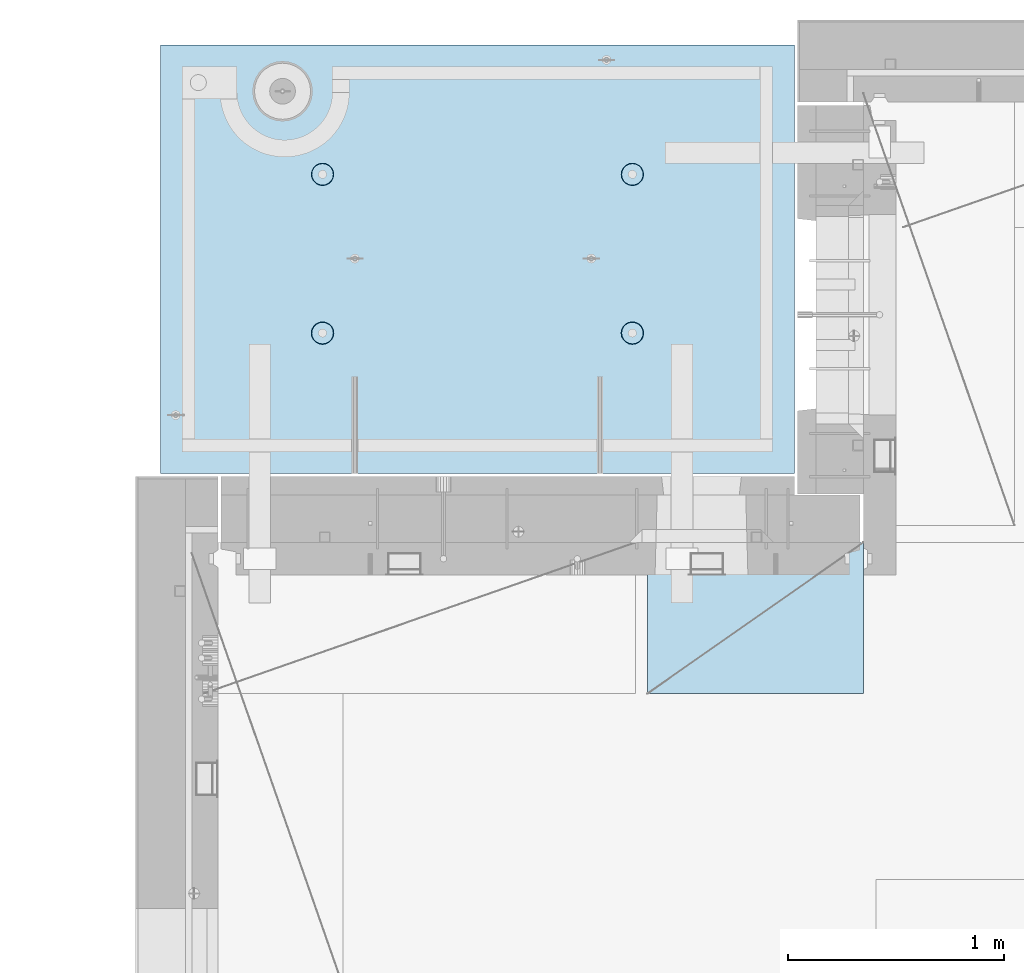
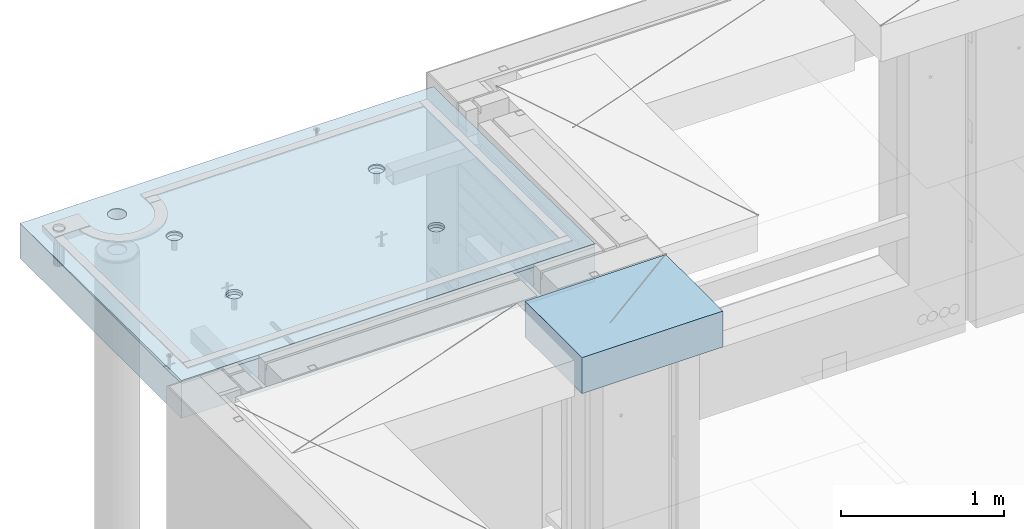
# One storey, part 205 of 349: 2 slabs, 1 plate, 2 elements without a shape of their own.
"""IFC2X3 building model written with IfcOpenShell, lengths in millimetres."""

import ifcopenshell
import ifcopenshell.guid

model = None  # the IFC model being written
_history = None  # IfcOwnerHistory: only IFC2X3 demands one
_inside = {}  # id of a spatial element -> (the spatial element, [elements in it])
_under = {}  # id of a project, library or spatial element -> (it, [spatial elements below it])
_declared = {}  # id of a project -> (the project, [libraries it declares])
_typed = {}  # id of a type object -> (the type object, [elements of that type])
_made_of = {}  # id of a material, layer set ... -> (it, [elements and type objects made of it])


def new_model(schema):
    """Start an empty IFC model of exactly this schema.

    Asked for "IFC4X3", IfcOpenShell would pick the latest addendum, in which some entities
    have other attributes; the version numbers below select the first issue.
    IFC2X3 requires an IfcOwnerHistory on every rooted entity: one is made here for all.
    """
    global model, _history
    if schema == "IFC4X3":
        model = ifcopenshell.file(schema_version=(4, 3, 0, 0))
    else:
        model = ifcopenshell.file(schema=schema)
    _inside.clear()
    _under.clear()
    _declared.clear()
    _typed.clear()
    _made_of.clear()
    _history = None
    if model.schema == "IFC2X3":
        org = make("IfcOrganization", Name="unknown")
        user = make(
            "IfcPersonAndOrganization",
            ThePerson=make("IfcPerson", FamilyName="unknown"),
            TheOrganization=org,
        )
        app = make(
            "IfcApplication",
            ApplicationDeveloper=org,
            Version="unknown",
            ApplicationFullName="unknown",
            ApplicationIdentifier="unknown",
        )
        _history = make(
            "IfcOwnerHistory",
            OwningUser=user,
            OwningApplication=app,
            ChangeAction="ADDED",
            CreationDate=0,
        )
    return model


def make(cls, **values):
    """One entity of the class cls with the attributes given. An attribute that is None is left unset."""
    return model.create_entity(
        cls, **{name: value for name, value in values.items() if value is not None}
    )


def rooted(cls, **values):
    """An entity with a GlobalId (a new one), such as an element, a storey or a relation."""
    return make(cls, GlobalId=ifcopenshell.guid.new(), OwnerHistory=_history, **values)


def si_unit(unit_type, name, prefix=None):
    """IfcSIUnit, for example si_unit("LENGTHUNIT", "METRE", prefix="MILLI")."""
    return make("IfcSIUnit", UnitType=unit_type, Prefix=prefix, Name=name)


def assignment(units):
    """IfcUnitAssignment: the units of a project."""
    return None if units is None else make("IfcUnitAssignment", Units=units)


def point(xyz):
    """IfcCartesianPoint."""
    return None if xyz is None else make("IfcCartesianPoint", Coordinates=xyz)


def direction(xyz):
    """IfcDirection."""
    return None if xyz is None else make("IfcDirection", DirectionRatios=xyz)


def frame(location, z_axis=None, x_axis=None):
    """IfcAxis2Placement3D, a coordinate frame: its origin and axes. An axis left out is left unset."""
    return make(
        "IfcAxis2Placement3D",
        Location=point(location),
        Axis=direction(z_axis),
        RefDirection=direction(x_axis),
    )


def origin_with_axes():
    """The frame at (0, 0, 0) with the z axis (0, 0, 1) and the x axis (1, 0, 0) written out."""
    return frame((0.0, 0.0, 0.0), z_axis=(0.0, 0.0, 1.0), x_axis=(1.0, 0.0, 0.0))


def place(relative_to, where):
    """IfcLocalPlacement: puts the frame where relative to a parent placement (None: the world)."""
    return make(
        "IfcLocalPlacement", PlacementRelTo=relative_to, RelativePlacement=where
    )


def context(
    kind, dimensions, precision=None, world=None, true_north=None, identifier=None
):
    """IfcGeometricRepresentationContext, for example the 3D "Model" context."""
    return make(
        "IfcGeometricRepresentationContext",
        ContextIdentifier=identifier,
        ContextType=kind,
        CoordinateSpaceDimension=dimensions,
        Precision=precision,
        WorldCoordinateSystem=world,
        TrueNorth=true_north,
    )


def subcontext(parent, identifier, kind, view, scale=None):
    """IfcGeometricRepresentationSubContext, for example "Body" below "Model"."""
    return make(
        "IfcGeometricRepresentationSubContext",
        ContextIdentifier=identifier,
        ContextType=kind,
        ParentContext=parent,
        TargetScale=scale,
        TargetView=view,
    )


def project(units=None, contexts=None):
    """IfcProject with its units and contexts."""
    return rooted(
        "IfcProject",
        Name="project",
        RepresentationContexts=contexts,
        UnitsInContext=assignment(units),
    )


def spatial(cls, under=None, at=None, **own):
    """A site, building, storey or space (cls), placed at a placement, below another one or the project."""
    s = rooted(cls, ObjectPlacement=at, **own)
    if under is not None:
        _under.setdefault(under.id(), (under, []))[1].append(s)
    return s


def faces_of(points, faces, orient=None, outer=None):
    """IfcFace entities. A face is a list of loops; a loop is a list of indices into points, from 0.

    orient and outer hold one flag for each loop. By default every Orientation is true, the
    first loop of a face is its IfcFaceOuterBound and the others are IfcFaceBound.
    """
    made = []
    for i, loops in enumerate(faces):
        bounds = []
        for j, loop in enumerate(loops):
            is_outer = j == 0 if outer is None else outer[i][j]
            bounds.append(
                make(
                    "IfcFaceOuterBound" if is_outer else "IfcFaceBound",
                    Bound=make("IfcPolyLoop", Polygon=[points[k] for k in loop]),
                    Orientation=True if orient is None else orient[i][j],
                )
            )
        made.append(make("IfcFace", Bounds=bounds))
    return made


def faceted_brep(points, faces, orient=None, outer=None, voids=None):
    """IfcFacetedBrep: a solid bounded by flat faces; with voids (closed shells), ...WithVoids."""
    shared = [point(p) for p in points]
    hull = make("IfcClosedShell", CfsFaces=faces_of(shared, faces, orient, outer))
    if voids is None:
        return make("IfcFacetedBrep", Outer=hull)
    return make(
        "IfcFacetedBrepWithVoids",
        Outer=hull,
        Voids=[
            make(cls, CfsFaces=faces_of(shared, fs, o, b)) for cls, fs, o, b in voids
        ],
    )


def shape(context_of_items, identifier, shape_type, items):
    """IfcShapeRepresentation: the items that make up one representation, for example the "Body"."""
    return make(
        "IfcShapeRepresentation",
        ContextOfItems=context_of_items,
        RepresentationIdentifier=identifier,
        RepresentationType=shape_type,
        Items=items,
    )


def material(Name=None, Category=None):
    """IfcMaterial."""
    return make("IfcMaterial", Name=Name, Category=Category)


def made_of(thing, what):
    """Note that an element or type object is made of a material, layer set ...; save() writes the relation."""
    if what is not None:
        _made_of.setdefault(what.id(), (what, []))[1].append(thing)
    return thing


def type_object(cls, material=None, **own):
    """A type object (cls), such as IfcWallType, which elements share."""
    return made_of(rooted(cls, **own), material)


def element(
    cls,
    number,
    at=None,
    inside=None,
    cuts=None,
    type_object=None,
    material=None,
    context=None,
    identifier="Body",
    shape_type=None,
    held_by="IfcProductDefinitionShape",
    body=None,
    shapes=None,
    **own,
):
    """One element of the class cls, such as IfcWall. Its Tag is "e" and its number.

    at: its placement. inside: the storey or other place that contains it. cuts: it is an
    opening in that element (IfcRelVoidsElement). A single representation is given by context,
    identifier, shape_type and body (its items); several are given by shapes. held_by: the class
    of the entity that holds the representations. save() writes the other relations.
    """
    e = rooted(cls, Tag="e%d" % number, ObjectPlacement=at, **own)
    if body is not None:
        shapes = [shape(context, identifier, shape_type, body)]
    if shapes is not None:
        e.Representation = make(held_by, Representations=shapes)
    if inside is not None:
        _inside.setdefault(inside.id(), (inside, []))[1].append(e)
    if cuts is not None:
        rooted(
            "IfcRelVoidsElement", RelatingBuildingElement=cuts, RelatedOpeningElement=e
        )
    if type_object is not None:
        _typed.setdefault(type_object.id(), (type_object, []))[1].append(e)
    return made_of(e, material)


def aggregate(whole, parts):
    """IfcRelAggregates: a whole, such as a stair, and the parts it consists of."""
    return rooted("IfcRelAggregates", RelatingObject=whole, RelatedObjects=parts)


def save(model, path):
    """Write the relations noted so far, then the file.

    IfcRelAggregates (storeys below a building ...), IfcRelContainedInSpatialStructure (elements
    in a storey), IfcRelDefinesByType, IfcRelAssociatesMaterial and IfcRelDeclares: one each for
    every whole, place, type object, material and project.
    """
    for whole, parts in _under.values():
        aggregate(whole, parts)
    for where, things in _inside.values():
        rooted(
            "IfcRelContainedInSpatialStructure",
            RelatedElements=things,
            RelatingStructure=where,
        )
    for kind, things in _typed.values():
        rooted("IfcRelDefinesByType", RelatedObjects=things, RelatingType=kind)
    for what, things in _made_of.values():
        rooted("IfcRelAssociatesMaterial", RelatedObjects=things, RelatingMaterial=what)
    for by, libraries in _declared.values():
        rooted("IfcRelDeclares", RelatingContext=by, RelatedDefinitions=libraries)
    model.write(path)


model = new_model("IFC2X3")

# Units and contexts
model_context = context("Model", 3, precision=1e-05, world=origin_with_axes())
body_context = subcontext(model_context, "Body", "Model", "MODEL_VIEW")
ifc_project = project(units=[si_unit("LENGTHUNIT", "METRE", prefix="MILLI"), si_unit("AREAUNIT", "SQUARE_METRE"), si_unit("VOLUMEUNIT", "CUBIC_METRE"), si_unit("MASSUNIT", "GRAM", prefix="KILO"), si_unit("TIMEUNIT", "SECOND"), si_unit("PLANEANGLEUNIT", "RADIAN"), si_unit("SOLIDANGLEUNIT", "STERADIAN"), si_unit("THERMODYNAMICTEMPERATUREUNIT", "DEGREE_CELSIUS"), si_unit("LUMINOUSINTENSITYUNIT", "LUMEN")], contexts=[model_context])

# Site, building, storey
site_placement = place(None, origin_with_axes())
site = spatial("IfcSite", under=ifc_project, at=site_placement, CompositionType="ELEMENT")
building_placement = place(site_placement, origin_with_axes())
building = spatial("IfcBuilding", under=site, at=building_placement, CompositionType="ELEMENT")
storey_placement = place(building_placement, origin_with_axes())
storey = spatial("IfcBuildingStorey", under=building, at=storey_placement, Name="4", CompositionType="ELEMENT", Elevation=0.0)

# Assembly, slabs
assembly_1_placement = place(storey_placement, origin_with_axes())
assembly_1 = element("IfcElementAssembly", 1, at=assembly_1_placement, inside=storey, AssemblyPlace="NOTDEFINED", PredefinedType="REINFORCEMENT_UNIT")
ifc_material_1 = material(Name="CONCRETE/C35/45")
slab_type_1 = type_object("IfcSlabType", PredefinedType="NOTDEFINED")
slab_1_placement = place(assembly_1_placement, frame((7734.99985681325, 20899.9965573523, 93717.5), z_axis=(0.0, 1.0, 0.0), x_axis=(1.0, 0.0, 0.0)))
slab_1 = element("IfcSlab", 2, at=slab_1_placement, type_object=slab_type_1, material=ifc_material_1, PredefinedType="FLOOR", context=body_context, shape_type="Brep", body=[
    faceted_brep([(209.64691778923, 8.87688398158934, 1795.66138892724), (209.64691778923, 12.5000000975269, 1795.66138892724), (201.519156607756, 12.5000000956934, 1783.49470026561), (201.519156607756, 8.73204270274437, 1783.49470026561), (189.354094229504, 12.5000000940054, 1775.36450517907), (189.354094229504, 8.63525483493868, 1775.36450517907), (175.003751124998, 12.5000000927103, 1772.50855216914), (175.003751124998, 8.60125545370101, 1772.50855216914), (160.652836945715, 12.5000000920118, 1775.36163419229), (160.652836945715, 8.63522065659345, 1775.36163419229), (148.48614828409, 12.5000000919972, 1783.48939537376), (148.48614828409, 8.73197954936768, 1783.48939537376), (140.355953197546, 12.5000000926811, 1795.65445775201), (140.355953197546, 8.87680146773346, 1795.65445775201), (137.500000187611, 12.5000000939617, 1810.00480085652), (137.500000187611, 9.04763858744991, 1810.00480085652), (140.353082210766, 12.5000000956497, 1824.35571503581), (140.353082210766, 9.21848250564653, 1824.35571503581), (148.48084339224, 12.5000000974687, 1836.52240369743), (148.48084339224, 9.36332378449151, 1836.52240369743), (160.645905770492, 12.5000000991568, 1844.65259878397), (160.645905770492, 9.4601116522972, 1844.65259878397), (174.996248874998, 12.5000001004519, 1847.50855179391), (174.996248874998, 9.49411103353486, 1847.50855179391), (189.347163054282, 12.5000001011649, 1844.65546977075), (189.347163054282, 9.46014583064243, 1844.65546977075), (201.513851715907, 12.5000001011795, 1836.52770858928), (201.513851715907, 9.3633869378682, 1836.52770858928), (209.64404680245, 12.500000100481, 1824.36264621103), (209.64404680245, 9.21856501948787, 1824.36264621103), (212.499999812386, 12.5000000992004, 1810.01230310652), (212.499999812386, 9.04772789980052, 1810.01230310652), (0.0, 12.5, 1985.00366210938), (7.41420080885291e-08, 12.4999999999927, 0.0), (-7.41420080885291e-08, -12.5, -3.63797880709171e-12), (0.0, 11.1309547276614, 1985.00366210938), (2935.0, 12.5000004097383, 1985.00366209901), (2935.0, 11.1309547276614, 1985.00366210938), (2935.0, 12.5, 0.0), (2935.0, -12.5, 0.0), (2234.65136896188, -4.56985165992228, 666.133623356985), (2233.6850359994, 12.5000001221924, 665.819642744358), (2236.1904762364, 12.5000001207372, 650.000915653603), (2237.21797072983, -4.76190736876742, 650.000915653603), (2227.22763735012, -4.39666783543362, 680.68109000706), (2226.41396523543, 12.5000001231529, 680.089922611885), (2215.67536748502, -4.25927704213245, 692.221936790684), (2215.08900701139, 12.5000001235312, 691.414880835895), (2201.12537297611, -4.17108941465267, 699.629710429519), (2200.81872714385, 12.5000001232838, 698.685951599829), (2185.00000005312, -4.14070613867079, 702.181910066618), (2185.00000005312, 12.5000001224398, 701.19139183679), (2168.87462713012, -4.17108941465267, 699.629710429519), (2169.18127296234, 12.5000001210865, 698.685951599953), (2154.32463262121, -4.25927704213245, 692.221936790684), (2154.9109930947, 12.5000001193257, 691.414880836099), (2142.77236275611, -4.39666783543362, 680.68109000706), (2143.58603487053, 12.5000001173757, 680.089922612086), (2135.34863114435, -4.56985165992228, 666.133623356985), (2136.31496410644, 12.5000001153967, 665.819642744485), (2132.7820293764, -4.76190736876742, 650.000915653603), (2133.8095238694, 12.5000001135923, 650.000915653603), (2135.3268816397, -4.95404720651277, 633.861141107776), (2136.31496410626, 12.5000001121371, 634.182188562663), (2142.73717131393, -5.12745128343522, 619.29517322078), (2143.58603487023, 12.5000001111621, 619.911908694903), (2154.28944117357, -5.26511432380357, 607.731457644233), (2154.9109930944, 12.5000001107837, 608.586950470697), (2168.85287761663, -5.35352220384812, 600.305182758089), (2169.18127296215, 12.5000001110311, 601.315879706683), (2185.00000005312, -5.38398960883205, 597.745916272124), (2185.00000005312, 12.5000001118751, 598.810439469788), (2201.1471224896, -5.35352220384812, 600.305182758089), (2200.81872714404, 12.500000113243, 601.31587970681), (2215.71055893266, -5.26511432380357, 607.731457644233), (2215.08900701168, 12.5000001149892, 608.586950470901), (2227.2628287923, -5.12745128343522, 619.29517322078), (2226.41396523573, 12.5000001169392, 619.911908695103), (2234.67311846653, -4.95404720651277, 633.861141107776), (2233.68503599959, 12.5000001189328, 634.182188562787), (799.651368961879, -4.56985165992228, 666.133623356985), (798.685036005074, 12.5000000220316, 665.819642746203), (801.190476242367, 12.5000000205619, 650.000915653603), (802.217970729829, -4.76190736876742, 650.000915653603), (792.227637350119, -4.39666783543362, 680.68109000706), (791.41396524025, 12.500000022992, 680.089922615389), (780.675367485019, -4.25927704213245, 692.221936790684), (780.089007014889, 12.5000000233704, 691.414880840719), (766.125372976112, -4.17108941465267, 699.629710429519), (765.818727145695, 12.500000023123, 698.685951605497), (750.000000053116, -4.14070613867079, 702.181910066618), (750.000000053116, 12.500000022279, 701.191391842753), (733.874627130121, -4.17108941465267, 699.629710429519), (734.181272960497, 12.5000000209257, 698.685951605625), (719.324632621214, -4.25927704213245, 692.221936790684), (719.910993091196, 12.5000000191649, 691.414880840923), (707.772362756114, -4.39666783543362, 680.68109000706), (708.586034865702, 12.5000000172149, 680.089922615593), (700.348631144354, -4.56985165992228, 666.133623356985), (701.314964100775, 12.5000000152359, 665.819642746326), (697.782029376403, -4.76190736876742, 650.000915653603), (698.80952386344, 12.5000000134314, 650.000915653603), (700.326881639705, -4.95404720651277, 633.861141107776), (701.314964100589, 12.5000000119617, 634.182188560822), (707.737171313933, -5.12745128343522, 619.29517322078), (708.586034865404, 12.5000000110012, 619.911908691396), (719.289441173572, -5.26511432380357, 607.731457644233), (719.910993090896, 12.5000000106229, 608.586950465873), (733.852877616633, -5.35352220384812, 600.305182758089), (734.181272960313, 12.5000000108703, 601.315879701015), (750.000000053116, -5.38398960883205, 597.745916272124), (750.000000053116, 12.5000000117143, 598.810439463825), (766.1471224896, -5.35352220384812, 600.305182758089), (765.818727145879, 12.5000000130822, 601.315879701138), (780.71055893266, -5.26511432380357, 607.731457644233), (780.089007015189, 12.5000000148284, 608.586950466077), (792.2628287923, -5.12745128343522, 619.29517322078), (791.413965240548, 12.5000000167784, 619.9119086916), (799.673118466528, -4.95404720651277, 633.861141107776), (798.685036005258, 12.500000018772, 634.182188560946), (799.156135017123, 4.17823925742414, 1400.9745431382), (798.685035917459, 12.5000000978907, 1400.82147376184), (801.190476154532, 12.5000000964355, 1385.00274667064), (801.697136924844, 3.98809915517631, 1385.00274667064), (791.806449365287, 4.3496957076859, 1415.37691010137), (791.413965153277, 12.5000000988512, 1415.09175362977), (780.369404424282, 4.48571613449894, 1426.80264589727), (780.089006928914, 12.5000000992295, 1426.4167118541), (765.96453481571, 4.57302415884624, 1434.13653274457), (765.818727060978, 12.5000000989821, 1433.68778261824), (749.999999969796, 4.6031043852272, 1436.66327617152), (749.999999969796, 12.5000000981381, 1436.19322285528), (734.035465123881, 4.57302415884624, 1434.13653274457), (734.181272878572, 12.5000000967848, 1433.68778261837), (719.630595515309, 4.48571613449894, 1426.80264589727), (719.91099301053, 12.5000000950386, 1426.41671185431), (708.193550574304, 4.3496957076859, 1415.37691010137), (708.586034786036, 12.5000000930741, 1415.09175362997), (700.843864922468, 4.17823925742414, 1400.9745431382), (701.314964021747, 12.500000091095, 1400.82147376197), (698.302863014747, 3.98809915517631, 1385.00274667064), (698.809523784634, 12.500000089276, 1385.00274667064), (700.822332352242, 3.79787576314993, 1369.0239538469), (701.314964021563, 12.5000000878208, 1369.18401957925), (708.15871013944, 3.62620125728427, 1354.60327018229), (708.586034785736, 12.5000000868604, 1354.91373971109), (719.595755075041, 3.48991129887872, 1343.15489369192), (719.91099301023, 12.500000086482, 1343.58878148656), (734.013932544907, 3.40238521881111, 1335.80269013289), (734.181272878388, 12.5000000867294, 1336.31771072235), (749.999999969796, 3.37222170254972, 1333.26895034341), (749.999999969796, 12.5000000875589, 1333.81227048538), (765.986067394684, 3.40238521881111, 1335.80269013289), (765.818727061163, 12.5000000889413, 1336.31771072247), (780.40424486455, 3.48991129887872, 1343.15489369192), (780.089006929215, 12.500000090673, 1343.58878148677), (791.841289800152, 3.62620125728427, 1354.60327018229), (791.413965153577, 12.5000000926375, 1354.91373971129), (799.17766758735, 3.79787576314993, 1369.0239538469), (798.685035917644, 12.5000000946166, 1369.18401957938), (2234.15613501712, 4.17823925742414, 1400.9745431382), (2233.68503591179, 12.5000001980516, 1400.82147376), (2236.19047614857, 12.5000001965964, 1385.00274667064), (2236.69713692484, 3.98809915517631, 1385.00274667064), (2226.80644936529, 4.3496957076859, 1415.37691010137), (2226.41396514845, 12.5000001990265, 1415.09175362627), (2215.36940442428, 4.48571613449894, 1426.80264589727), (2215.08900692541, 12.5000001993903, 1426.41671184928), (2200.96453481571, 4.57302415884624, 1434.13653274457), (2200.81872705914, 12.5000001991575, 1433.68778261257), (2184.9999999698, 4.6031043852272, 1436.66327617152), (2184.9999999698, 12.5000001982989, 1436.19322284931), (2169.03546512388, 4.57302415884624, 1434.13653274457), (2169.18127288041, 12.5000001969456, 1433.6877826127), (2154.63059551531, 4.48571613449894, 1426.80264589727), (2154.91099301403, 12.5000001951994, 1426.41671184948), (2143.1935505743, 4.3496957076859, 1415.37691010137), (2143.58603479086, 12.5000001932349, 1415.09175362647), (2135.84386492247, 4.17823925742414, 1400.9745431382), (2136.31496402742, 12.5000001912558, 1400.82147376013), (2133.30286301475, 3.98809915517631, 1385.00274667064), (2133.8095237906, 12.5000001894368, 1385.00274667064), (2135.82233235224, 3.79787576314993, 1369.0239538469), (2136.31496402723, 12.5000001879816, 1369.18401958109), (2143.15871013944, 3.62620125728427, 1354.60327018229), (2143.58603479056, 12.5000001870212, 1354.91373971459), (2154.59575507504, 3.48991129887872, 1343.15489369192), (2154.91099301373, 12.5000001866429, 1343.58878149139), (2169.01393254491, 3.40238521881111, 1335.80269013289), (2169.18127288023, 12.5000001868902, 1336.31771072802), (2184.9999999698, 3.37222170254972, 1333.26895034341), (2184.9999999698, 12.5000001877343, 1333.81227049134), (2200.98606739468, 3.40238521881111, 1335.80269013289), (2200.81872705932, 12.5000001891021, 1336.31771072814), (2215.40424486455, 3.48991129887872, 1343.15489369192), (2215.08900692571, 12.5000001908338, 1343.58878149159), (2226.84128980015, 3.62620125728427, 1354.60327018229), (2226.41396514875, 12.5000001927983, 1354.9137397148), (2234.17766758735, 3.79787576314993, 1369.0239538469), (2233.68503591197, 12.5000001947919, 1369.18401958122), (613.539958053605, 8.15176414522284, 1734.75121634823), (600.266053528658, 7.99374174815603, 1721.47731182328), (583.539958053605, 7.89228512388945, 1712.95494050807), (564.998938391109, 7.85732555369032, 1710.01833148578), (546.457918728613, 7.89228512388945, 1712.95494050807), (529.73182325356, 7.99374174815603, 1721.47731182328), (516.457918728613, 8.15176414522284, 1734.75121634823), (507.935547413399, 8.35088398186781, 1751.47731182328), (504.998938391109, 8.57161002114299, 1770.01833148578), (507.935547413399, 8.79233606038906, 1788.55935114828), (516.457918728613, 8.99145589703403, 1805.28544662333), (529.73182325356, 9.1494782941154, 1818.55935114828), (546.457918728613, 9.25093491838197, 1827.08172246349), (564.998938391109, 9.28589448856656, 1830.01833148578), (583.539958053605, 9.25093491838197, 1827.08172246349), (600.266053528658, 9.1494782941154, 1818.55935114828), (613.539958053605, 8.99145589703403, 1805.28544662333), (622.062329368819, 8.79233606038906, 1788.55935114828), (624.998938391109, 8.57161002114299, 1770.01833148578), (622.062329368819, 8.35088398186781, 1751.47731182328), (613.539958053605, 12.5, 1805.28544662333), (622.062329368819, 12.5, 1788.55935114828), (600.266053528658, 12.5, 1818.55935114828), (583.539958053605, 12.5, 1827.08172246349), (564.998938391109, 12.5, 1830.01833148578), (546.457918728613, 12.5, 1827.08172246349), (529.73182325356, 12.5, 1818.55935114828), (516.457918728613, 12.5, 1805.28544662333), (507.935547413399, 12.5, 1788.55935114828), (504.998938391109, 12.5, 1770.01833148578), (507.935547413399, 12.5, 1751.47731182328), (516.457918728613, 12.5, 1734.75121634823), (529.73182325356, 12.5, 1721.47731182328), (546.457918728613, 12.5, 1712.95494050807), (564.998938391109, 12.5, 1710.01833148578), (583.539958053605, 12.5, 1712.95494050807), (600.266053528658, 12.5, 1721.47731182328), (613.539958053605, 12.5, 1734.75121634823), (622.062329368819, 12.5, 1751.47731182328), (624.998938391109, 12.5, 1770.01833148578)], [[[0, 1, 2, 3]], [[3, 2, 4, 5]], [[5, 4, 6, 7]], [[7, 6, 8, 9]], [[9, 8, 10, 11]], [[11, 10, 12, 13]], [[13, 12, 14, 15]], [[15, 14, 16, 17]], [[17, 16, 18, 19]], [[19, 18, 20, 21]], [[21, 20, 22, 23]], [[23, 22, 24, 25]], [[25, 24, 26, 27]], [[27, 26, 28, 29]], [[29, 28, 30, 31]], [[31, 30, 1, 0]], [[32, 33, 34, 35]], [[36, 32, 35, 37]], [[38, 36, 37, 39]], [[33, 38, 39, 34]], [[40, 41, 42, 43]], [[44, 45, 41, 40]], [[46, 47, 45, 44]], [[48, 49, 47, 46]], [[50, 51, 49, 48]], [[52, 53, 51, 50]], [[53, 52, 54, 55]], [[55, 54, 56, 57]], [[57, 56, 58, 59]], [[59, 58, 60, 61]], [[61, 60, 62, 63]], [[63, 62, 64, 65]], [[65, 64, 66, 67]], [[67, 66, 68, 69]], [[69, 68, 70, 71]], [[72, 73, 71, 70]], [[74, 75, 73, 72]], [[76, 77, 75, 74]], [[78, 79, 77, 76]], [[43, 42, 79, 78]], [[80, 81, 82, 83]], [[84, 85, 81, 80]], [[86, 87, 85, 84]], [[88, 89, 87, 86]], [[90, 91, 89, 88]], [[92, 93, 91, 90]], [[93, 92, 94, 95]], [[95, 94, 96, 97]], [[97, 96, 98, 99]], [[99, 98, 100, 101]], [[101, 100, 102, 103]], [[103, 102, 104, 105]], [[105, 104, 106, 107]], [[107, 106, 108, 109]], [[109, 108, 110, 111]], [[112, 113, 111, 110]], [[114, 115, 113, 112]], [[116, 117, 115, 114]], [[118, 119, 117, 116]], [[83, 82, 119, 118]], [[120, 121, 122, 123]], [[124, 125, 121, 120]], [[126, 127, 125, 124]], [[128, 129, 127, 126]], [[130, 131, 129, 128]], [[132, 133, 131, 130]], [[134, 135, 133, 132]], [[135, 134, 136, 137]], [[137, 136, 138, 139]], [[139, 138, 140, 141]], [[141, 140, 142, 143]], [[143, 142, 144, 145]], [[145, 144, 146, 147]], [[147, 146, 148, 149]], [[149, 148, 150, 151]], [[151, 150, 152, 153]], [[154, 155, 153, 152]], [[156, 157, 155, 154]], [[158, 159, 157, 156]], [[123, 122, 159, 158]], [[160, 161, 162, 163]], [[164, 165, 161, 160]], [[166, 167, 165, 164]], [[168, 169, 167, 166]], [[170, 171, 169, 168]], [[172, 173, 171, 170]], [[174, 175, 173, 172]], [[175, 174, 176, 177]], [[177, 176, 178, 179]], [[179, 178, 180, 181]], [[181, 180, 182, 183]], [[183, 182, 184, 185]], [[185, 184, 186, 187]], [[187, 186, 188, 189]], [[189, 188, 190, 191]], [[191, 190, 192, 193]], [[194, 195, 193, 192]], [[196, 197, 195, 194]], [[198, 199, 197, 196]], [[163, 162, 199, 198]], [[37, 35, 34, 39], [3, 5, 7, 9, 11, 13, 15, 17, 19, 21, 23, 25, 27, 29, 31, 0], [200, 201, 202, 203, 204, 205, 206, 207, 208, 209, 210, 211, 212, 213, 214, 215, 216, 217, 218, 219], [196, 194, 192, 190, 188, 186, 184, 182, 180, 178, 176, 174, 172, 170, 168, 166, 164, 160, 163, 198], [156, 154, 152, 150, 148, 146, 144, 142, 140, 138, 136, 134, 132, 130, 128, 126, 124, 120, 123, 158], [116, 114, 112, 110, 108, 106, 104, 102, 100, 98, 96, 94, 92, 90, 88, 86, 84, 80, 83, 118], [76, 74, 72, 70, 68, 66, 64, 62, 60, 58, 56, 54, 52, 50, 48, 46, 44, 40, 43, 78]], [[216, 220, 221, 217]], [[215, 222, 220, 216]], [[214, 223, 222, 215]], [[213, 224, 223, 214]], [[212, 225, 224, 213]], [[211, 226, 225, 212]], [[210, 227, 226, 211]], [[209, 228, 227, 210]], [[208, 229, 228, 209]], [[207, 230, 229, 208]], [[206, 231, 230, 207]], [[205, 232, 231, 206]], [[204, 233, 232, 205]], [[203, 234, 233, 204]], [[202, 235, 234, 203]], [[201, 236, 235, 202]], [[200, 237, 236, 201]], [[219, 238, 237, 200]], [[218, 239, 238, 219]], [[217, 221, 239, 218]], [[38, 33, 32, 36], [26, 24, 22, 20, 18, 16, 14, 12, 10, 8, 6, 4, 2, 1, 30, 28], [220, 222, 223, 224, 225, 226, 227, 228, 229, 230, 231, 232, 233, 234, 235, 236, 237, 238, 239, 221], [165, 167, 169, 171, 173, 175, 177, 179, 181, 183, 185, 187, 189, 191, 193, 195, 197, 199, 162, 161], [125, 127, 129, 131, 133, 135, 137, 139, 141, 143, 145, 147, 149, 151, 153, 155, 157, 159, 122, 121], [85, 87, 89, 91, 93, 95, 97, 99, 101, 103, 105, 107, 109, 111, 113, 115, 117, 119, 82, 81], [45, 47, 49, 51, 53, 55, 57, 59, 61, 63, 65, 67, 69, 71, 73, 75, 77, 79, 42, 41]]]),
])
slab_type_2 = type_object("IfcSlabType", PredefinedType="NOTDEFINED")
slab_2_placement = place(assembly_1_placement, frame((7734.99985681325, 20899.9965573523, 93575.0), z_axis=(-2.2639999995273e-06, 0.999999999997437, 0.0), x_axis=(0.999999999997251, 2.34499999952812e-06, 0.0)))
slab_2 = element("IfcSlab", 3, at=slab_2_placement, type_object=slab_type_2, material=ifc_material_1, PredefinedType="FLOOR", context=body_context, shape_type="Brep", body=[
    faceted_brep([(2200.45398600256, -110.0, 1337.44476079497), (2214.39241555253, -110.0, 1344.54670420538), (2225.45402859605, -110.0, 1355.60826537005), (2232.55603737762, -110.0, 1369.54666161175), (2235.0032477951, -110.0, 1384.99750559184), (2232.5561098421, -110.0, 1400.44836104917), (2225.45416643169, -110.0, 1414.38679059914), (2214.39260526702, -110.0, 1425.44840364265), (2200.45420902531, -110.0, 1432.55041242422), (2185.00336504523, -110.0, 1434.9976228417), (2169.55250958791, -110.0, 1432.55048488871), (2155.61408003793, -110.0, 1425.44854147829), (2144.55246699442, -110.0, 1414.38698031362), (2137.45045821285, -110.0, 1400.44858407192), (2135.00324779537, -110.0, 1384.99774009184), (2137.45038574836, -110.0, 1369.54688463451), (2144.55232915878, -110.0, 1355.60845508454), (2155.61389032345, -110.0, 1344.54684204102), (2169.55228656515, -110.0, 1337.44483325945), (2185.00313054523, -110.0, 1334.99762284198), (2226.41728354208, -130.0, 1415.08653268859), (2233.68832084322, -130.0, 1400.81623576839), (2215.09235187349, -130.0, 1426.41151747124), (2200.8220890546, -130.0, 1433.68262169999), (2185.0033678369, -130.0, 1436.18809903217), (2169.18463486868, -130.0, 1433.68269588982), (2154.91433794847, -130.0, 1426.41165858869), (2143.58935316583, -130.0, 1415.08672692009), (2136.31824893708, -130.0, 1400.81646410121), (2133.8127716049, -130.0, 1384.9977428835), (2136.31817474725, -130.0, 1369.17900991529), (2143.58921204838, -130.0, 1354.90871299508), (2154.91414371698, -130.0, 1343.58372821243), (2169.18440653586, -130.0, 1336.31262398369), (2185.00312775357, -130.0, 1333.8071466515), (2200.82186072178, -130.0, 1336.31254979386), (2215.09215764199, -130.0, 1343.58358709499), (2226.41714242464, -130.0, 1354.90851876358), (2233.68824665339, -130.0, 1369.17878158247), (2236.19372398557, -130.0, 1384.99750280017), (765.453986006505, -110.0, 1337.44812586997), (779.392415556478, -110.0, 1344.55006928038), (790.454028599992, -110.0, 1355.61163044505), (797.556037381562, -110.0, 1369.55002668675), (800.003247799041, -110.0, 1385.00087066684), (797.556109846048, -110.0, 1400.45172612417), (790.454166435635, -110.0, 1414.39015567414), (779.392605270965, -110.0, 1425.45176871765), (765.45420902926, -110.0, 1432.55377749922), (750.003365049179, -110.0, 1435.0009879167), (734.552509591851, -110.0, 1432.55384996371), (720.614080041878, -110.0, 1425.4519065533), (709.552466998364, -110.0, 1414.39034538862), (702.450458216794, -110.0, 1400.45194914692), (700.003247799315, -110.0, 1385.00110516684), (702.450385752309, -110.0, 1369.5502497095), (709.552329162721, -110.0, 1355.61182015954), (720.613890327391, -110.0, 1344.55020711602), (734.552286569096, -110.0, 1337.44819833446), (750.003130549179, -110.0, 1335.00098791698), (798.688320847163, -130.0, 1400.81960084339), (801.193723989514, -130.0, 1385.00086787517), (791.417283546027, -130.0, 1415.0898977636), (780.092351877434, -130.0, 1426.41488254624), (765.822089058547, -130.0, 1433.68598677499), (750.003367840845, -130.0, 1436.19146410717), (734.184634872629, -130.0, 1433.68606096482), (719.914337952418, -130.0, 1426.41502366369), (708.589353169771, -130.0, 1415.09009199509), (701.318248941023, -130.0, 1400.81982917621), (698.812771608842, -130.0, 1385.00110795851), (701.318174751194, -130.0, 1369.18237499029), (708.589212052329, -130.0, 1354.91207807008), (719.914143720922, -130.0, 1343.58709328743), (734.184406539811, -130.0, 1336.31598905868), (750.003127757513, -130.0, 1333.8105117265), (765.821860725729, -130.0, 1336.31591486885), (780.092157645939, -130.0, 1343.58695216999), (791.417142428585, -130.0, 1354.91188383858), (798.688246657333, -130.0, 1369.18214665747), (2935.0, -130.0, 1.16051523946226e-09), (0.0, -130.0, -3.63797880709171e-12), (0.0, 130.0, -1.81898940354586e-12), (2935.0, 130.0, 1.16051523946226e-09), (2935.00146484375, -130.0, 1985.00366210938), (2935.00146484375, 130.0, 1985.00366210938), (0.00127768016045593, -130.0, 1985.00366210937), (0.00127768016045593, 130.0, 1985.00366210937), (613.544191446293, 130.0, 1805.28400786653), (600.270318048689, 130.0, 1818.55794351875), (583.544242558642, 130.0, 1827.08035405663), (565.003229782545, 130.0, 1830.0170065576), (546.462203233751, 130.0, 1827.08044101401), (529.736087773786, 130.0, 1818.55810892152), (516.462152121568, 130.0, 1805.28423552391), (507.939741583684, 130.0, 1788.55816003387), (505.00308908271, 130.0, 1770.01714725777), (507.939654626302, 130.0, 1751.47612070897), (516.461986718798, 130.0, 1734.75000524901), (529.735860116402, 130.0, 1721.47606959679), (546.461935606448, 130.0, 1712.95365905891), (565.002948382545, 130.0, 1710.01700655793), (583.543974931338, 130.0, 1712.95357210152), (600.270090391306, 130.0, 1721.47590419402), (613.544026043523, 130.0, 1734.74977759163), (622.066436581407, 130.0, 1751.47585308167), (625.003089082381, 130.0, 1770.01686585777), (622.066523538789, 130.0, 1788.55789240656), (622.066523538789, -130.0, 1788.55789240656), (625.003089082381, -130.0, 1770.01686585777), (613.544191446293, -130.0, 1805.28400786653), (600.270318048689, -130.0, 1818.55794351875), (583.544242558642, -130.0, 1827.08035405663), (565.003229782545, -130.0, 1830.0170065576), (546.462203233751, -130.0, 1827.08044101401), (529.736087773786, -130.0, 1818.55810892152), (516.462152121568, -130.0, 1805.28423552391), (507.939741583684, -130.0, 1788.55816003387), (505.00308908271, -130.0, 1770.01714725777), (507.939654626302, -130.0, 1751.47612070897), (516.461986718798, -130.0, 1734.75000524901), (529.735860116402, -130.0, 1721.47606959679), (546.461935606448, -130.0, 1712.95365905891), (565.002948382545, -130.0, 1710.01700655793), (583.543974931338, -130.0, 1712.95357210152), (600.270090391306, -130.0, 1721.47590419402), (613.544026043523, -130.0, 1734.74977759163), (622.066436581407, -130.0, 1751.47585308167), (765.452262510529, -110.0, 602.446294854952), (779.390692060502, -110.0, 609.548238265361), (790.452305104016, -110.0, 620.609799430033), (797.554313885586, -110.0, 634.548195671738), (800.001524303065, -110.0, 649.999039651819), (797.554386350072, -110.0, 665.449895109152), (790.452442939657, -110.0, 679.388324659118), (779.390881774987, -110.0, 690.449937702637), (765.452485533282, -110.0, 697.551946484204), (750.001641553203, -110.0, 699.999156901682), (734.550786095873, -110.0, 697.552018948689), (720.6123565459, -110.0, 690.45007553828), (709.550743502386, -110.0, 679.388514373604), (702.448734720818, -110.0, 665.450118131903), (700.001524303339, -110.0, 649.999274151818), (702.448662256333, -110.0, 634.548418694489), (709.550605666745, -110.0, 620.609989144519), (720.612166831415, -110.0, 609.548376101004), (734.55056307312, -110.0, 602.446367319437), (750.001407053202, -110.0, 599.999156901958), (798.686597351187, -130.0, 665.817769828369), (801.192000493538, -130.0, 649.999036860154), (791.415560050051, -130.0, 680.088066748576), (780.090628381458, -130.0, 691.413051531228), (765.820365562571, -130.0, 698.684155759973), (750.001644344869, -130.0, 701.189633092159), (734.182911376653, -130.0, 698.684229949802), (719.912614456442, -130.0, 691.41319264867), (708.587629673795, -130.0, 680.088260980072), (701.316525445047, -130.0, 665.817998161187), (698.811048112866, -130.0, 649.999276943487), (701.316451255216, -130.0, 634.180543975268), (708.587488556352, -130.0, 619.910247055061), (719.912420224944, -130.0, 608.585262272412), (734.182683043833, -130.0, 601.314158043664), (750.001404261535, -130.0, 598.808680711485), (765.820137229752, -130.0, 601.314083853835), (780.090434149961, -130.0, 608.585121154971), (791.415418932607, -130.0, 619.910052823565), (798.686523161356, -130.0, 634.18031564245), (2200.45226250658, -110.0, 602.442929779951), (2214.39069205656, -110.0, 609.544873190363), (2225.45230510007, -110.0, 620.606434355035), (2232.55431388164, -110.0, 634.544830596737), (2235.00152429912, -110.0, 649.995674576818), (2232.55438634613, -110.0, 665.446530034151), (2225.45244293571, -110.0, 679.38495958412), (2214.39088177104, -110.0, 690.446572627639), (2200.45248552934, -110.0, 697.548581409203), (2185.00164154926, -110.0, 699.995791826681), (2169.55078609193, -110.0, 697.548653873688), (2155.61235654195, -110.0, 690.446710463279), (2144.55074349844, -110.0, 679.385149298603), (2137.44873471687, -110.0, 665.446753056905), (2135.00152429939, -110.0, 649.995909076821), (2137.44866225239, -110.0, 634.545053619491), (2144.5506056628, -110.0, 620.606624069518), (2155.61216682747, -110.0, 609.545011026003), (2169.55056306918, -110.0, 602.443002244436), (2185.00140704926, -110.0, 599.995791826957), (2233.68659734724, -130.0, 665.814404753368), (2236.19200048959, -130.0, 649.995671785153), (2226.41556004611, -130.0, 680.084701673575), (2215.09062837751, -130.0, 691.409686456227), (2200.82036555863, -130.0, 698.680790684972), (2185.00164434092, -130.0, 701.186268017158), (2169.18291137271, -130.0, 698.680864874805), (2154.9126144525, -130.0, 691.409827573672), (2143.58762966985, -130.0, 680.084895905075), (2136.3165254411, -130.0, 665.814633086189), (2133.81104810892, -130.0, 649.995911868486), (2136.31645125127, -130.0, 634.177178900271), (2143.58748855241, -130.0, 619.906881980063), (2154.912420221, -130.0, 608.581897197415), (2169.18268303989, -130.0, 601.310792968667), (2185.00140425759, -130.0, 598.805315636484), (2200.82013722581, -130.0, 601.310718778834), (2215.09043414602, -130.0, 608.58175607997), (2226.41541892866, -130.0, 619.906687748564), (2233.68652315741, -130.0, 634.176950567449)], [[[0, 1, 2, 3, 4, 5, 6, 7, 8, 9, 10, 11, 12, 13, 14, 15, 16, 17, 18, 19]], [[20, 6, 5, 21]], [[22, 7, 6, 20]], [[23, 8, 7, 22]], [[24, 9, 8, 23]], [[25, 10, 9, 24]], [[26, 11, 10, 25]], [[27, 12, 11, 26]], [[28, 13, 12, 27]], [[29, 14, 13, 28]], [[30, 15, 14, 29]], [[31, 16, 15, 30]], [[32, 17, 16, 31]], [[33, 18, 17, 32]], [[34, 19, 18, 33]], [[35, 0, 19, 34]], [[36, 1, 0, 35]], [[37, 2, 1, 36]], [[38, 3, 2, 37]], [[39, 4, 3, 38]], [[21, 5, 4, 39]], [[40, 41, 42, 43, 44, 45, 46, 47, 48, 49, 50, 51, 52, 53, 54, 55, 56, 57, 58, 59]], [[60, 45, 44, 61]], [[62, 46, 45, 60]], [[63, 47, 46, 62]], [[64, 48, 47, 63]], [[65, 49, 48, 64]], [[66, 50, 49, 65]], [[67, 51, 50, 66]], [[68, 52, 51, 67]], [[69, 53, 52, 68]], [[70, 54, 53, 69]], [[71, 55, 54, 70]], [[72, 56, 55, 71]], [[73, 57, 56, 72]], [[74, 58, 57, 73]], [[75, 59, 58, 74]], [[76, 40, 59, 75]], [[77, 41, 40, 76]], [[78, 42, 41, 77]], [[79, 43, 42, 78]], [[61, 44, 43, 79]], [[80, 81, 82, 83]], [[84, 80, 83, 85]], [[86, 84, 85, 87]], [[81, 86, 87, 82]], [[85, 83, 82, 87], [88, 89, 90, 91, 92, 93, 94, 95, 96, 97, 98, 99, 100, 101, 102, 103, 104, 105, 106, 107]], [[108, 107, 106, 109]], [[110, 88, 107, 108]], [[111, 89, 88, 110]], [[112, 90, 89, 111]], [[113, 91, 90, 112]], [[114, 92, 91, 113]], [[115, 93, 92, 114]], [[116, 94, 93, 115]], [[117, 95, 94, 116]], [[118, 96, 95, 117]], [[119, 97, 96, 118]], [[120, 98, 97, 119]], [[121, 99, 98, 120]], [[122, 100, 99, 121]], [[123, 101, 100, 122]], [[124, 102, 101, 123]], [[125, 103, 102, 124]], [[126, 104, 103, 125]], [[127, 105, 104, 126]], [[109, 106, 105, 127]], [[128, 129, 130, 131, 132, 133, 134, 135, 136, 137, 138, 139, 140, 141, 142, 143, 144, 145, 146, 147]], [[148, 133, 132, 149]], [[150, 134, 133, 148]], [[151, 135, 134, 150]], [[152, 136, 135, 151]], [[153, 137, 136, 152]], [[154, 138, 137, 153]], [[155, 139, 138, 154]], [[156, 140, 139, 155]], [[157, 141, 140, 156]], [[158, 142, 141, 157]], [[159, 143, 142, 158]], [[160, 144, 143, 159]], [[161, 145, 144, 160]], [[162, 146, 145, 161]], [[163, 147, 146, 162]], [[164, 128, 147, 163]], [[165, 129, 128, 164]], [[166, 130, 129, 165]], [[167, 131, 130, 166]], [[149, 132, 131, 167]], [[168, 169, 170, 171, 172, 173, 174, 175, 176, 177, 178, 179, 180, 181, 182, 183, 184, 185, 186, 187]], [[188, 173, 172, 189]], [[190, 174, 173, 188]], [[191, 175, 174, 190]], [[192, 176, 175, 191]], [[193, 177, 176, 192]], [[194, 178, 177, 193]], [[195, 179, 178, 194]], [[196, 180, 179, 195]], [[197, 181, 180, 196]], [[198, 182, 181, 197]], [[199, 183, 182, 198]], [[200, 184, 183, 199]], [[201, 185, 184, 200]], [[202, 186, 185, 201]], [[203, 187, 186, 202]], [[204, 168, 187, 203]], [[205, 169, 168, 204]], [[206, 170, 169, 205]], [[207, 171, 170, 206]], [[189, 172, 171, 207]], [[80, 84, 86, 81], [37, 36, 35, 34, 33, 32, 31, 30, 29, 28, 27, 26, 25, 24, 23, 22, 20, 21, 39, 38], [206, 205, 204, 203, 202, 201, 200, 199, 198, 197, 196, 195, 194, 193, 192, 191, 190, 188, 189, 207], [166, 165, 164, 163, 162, 161, 160, 159, 158, 157, 156, 155, 154, 153, 152, 151, 150, 148, 149, 167], [126, 125, 124, 123, 122, 121, 120, 119, 118, 117, 116, 115, 114, 113, 112, 111, 110, 108, 109, 127], [78, 77, 76, 75, 74, 73, 72, 71, 70, 69, 68, 67, 66, 65, 64, 63, 62, 60, 61, 79]]]),
])
aggregate(assembly_1, [slab_1, slab_2])

# Assembly, plate
assembly_2_placement = place(storey_placement, origin_with_axes())
assembly_2 = element("IfcElementAssembly", 4, at=assembly_2_placement, inside=storey, Name="Steel Assembly", AssemblyPlace="NOTDEFINED", PredefinedType="NOTDEFINED")
ifc_material_2 = material()
plate_type = type_object("IfcPlateType", PredefinedType="NOTDEFINED")
plate_placement = place(assembly_2_placement, frame((10990.0, 20580.0000000707, 93595.3), z_axis=(0.0, -1.0, 0.0), x_axis=(-1.0, 3.00000001838171e-08, 0.0)))
plate = element("IfcPlate", 5, at=plate_placement, type_object=plate_type, material=ifc_material_2, Name="RE1_1/2", context=body_context, shape_type="Brep", body=[
    faceted_brep([(1.81898940354586e-12, -135.0, 1.81898940354586e-12), (0.0, -135.0, 699.999999999996), (0.0, 135.0, 699.999999999996), (1.81898940354586e-12, 135.0, 1.81898940354586e-12), (999.99951171875, -135.0, 700.0), (999.99951171875, 135.0, 700.0), (1000.0, -135.0, 0.0), (1000.0, 135.0, 0.0)], [[[0, 1, 2, 3]], [[1, 4, 5, 2]], [[4, 6, 7, 5]], [[6, 0, 3, 7]], [[5, 7, 3, 2]], [[6, 4, 1, 0]]]),
])
aggregate(assembly_2, [plate])

save(model, "model.ifc")
